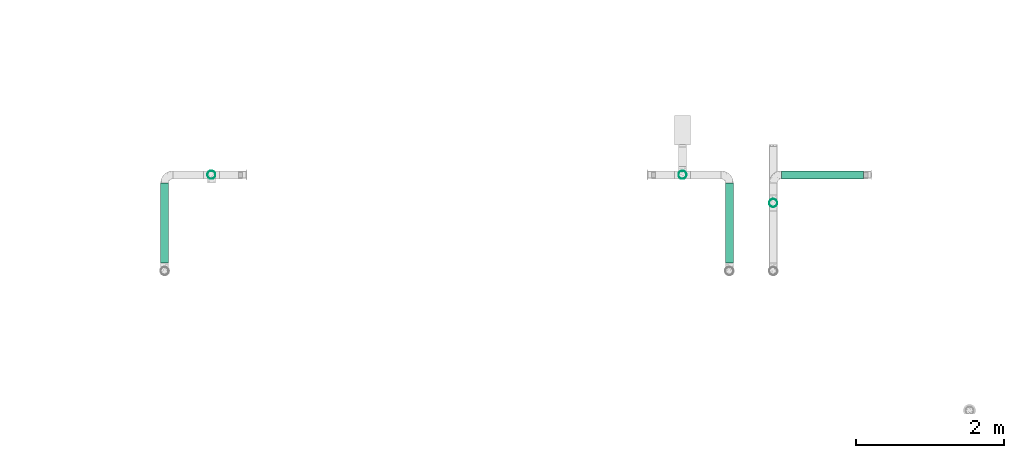
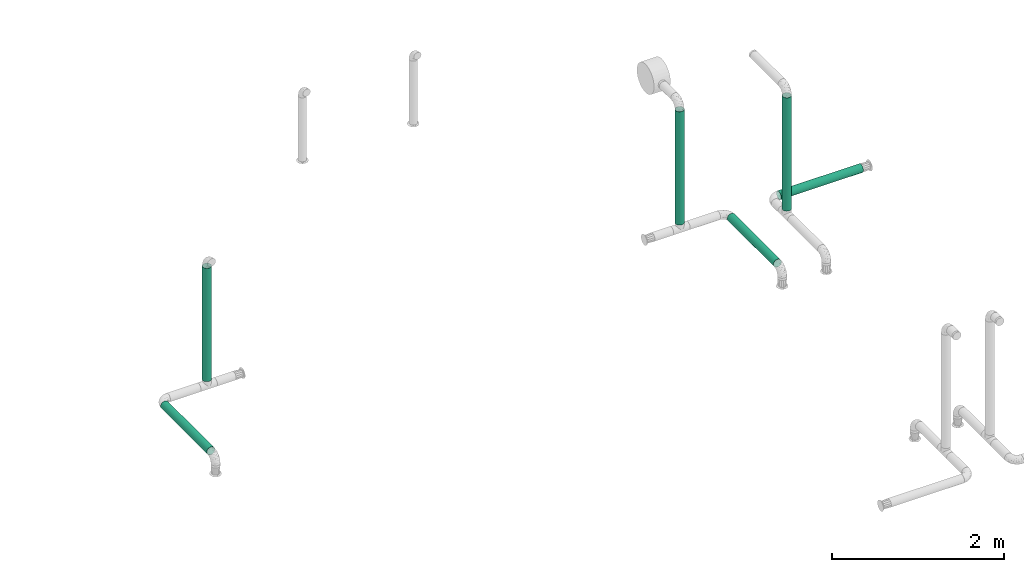
# One storey, part 4 of 103: 6 flow segments.
"""IFC2X3 building model written with IfcOpenShell, lengths in millimetres."""

from ifc_helpers import new_model, entity, si_unit, converted_unit, derived_unit, direction, frame, origin_with_axes, origin_2d_with_axis, place, context, subcontext, project, spatial, hollow_circle, extrude, source, transform, mapped, material, layer, layer_set, layer_usage, type_object, element, save


model = new_model("IFC2X3")

# Units and contexts
model_context = context("Model", 3, precision=1e-05, world=origin_with_axes(), true_north=direction((0.0, 1.0)))
body_context = subcontext(model_context, "Body", "Model", "MODEL_VIEW")
ifc_project = project(units=[si_unit("AREAUNIT", "SQUARE_METRE"), si_unit("VOLUMEUNIT", "CUBIC_METRE", prefix="DECI"), si_unit("TIMEUNIT", "SECOND"), si_unit("THERMODYNAMICTEMPERATUREUNIT", "DEGREE_CELSIUS"), si_unit("PRESSUREUNIT", "PASCAL"), si_unit("MASSUNIT", "GRAM", prefix="KILO"), si_unit("LENGTHUNIT", "METRE", prefix="MILLI"), si_unit("POWERUNIT", "WATT"), si_unit("ELECTRICCURRENTUNIT", "AMPERE"), si_unit("ELECTRICVOLTAGEUNIT", "VOLT"), derived_unit("VOLUMETRICFLOWRATEUNIT", [(si_unit("VOLUMEUNIT", "CUBIC_METRE", prefix="DECI"), 1), (si_unit("TIMEUNIT", "SECOND"), -1)]), derived_unit("LINEARVELOCITYUNIT", [(si_unit("LENGTHUNIT", "METRE"), 1), (si_unit("TIMEUNIT", "SECOND"), -1)]), derived_unit("MASSDENSITYUNIT", [(si_unit("MASSUNIT", "GRAM", prefix="KILO"), 1), (si_unit("VOLUMEUNIT", "CUBIC_METRE"), -1)]), converted_unit("PLANEANGLEUNIT", "DEGREE", entity("IfcRatioMeasure", 0.01745), si_unit("PLANEANGLEUNIT", "RADIAN"), dimensions=[0, 0, 0, 0, 0, 0, 0])], contexts=[model_context])

# Site, building, storey
site_placement = place(None, origin_with_axes())
site = spatial("IfcSite", under=ifc_project, at=site_placement, CompositionType="ELEMENT")
building_placement = place(site_placement, origin_with_axes())
building = spatial("IfcBuilding", under=site, at=building_placement, Name="mc-building", CompositionType="ELEMENT")
storey_placement = place(building_placement, frame((0.0, 0.0, 5900.0), z_axis=(0.0, 0.0, 1.0), x_axis=(1.0, 0.0, 0.0)))
storey = spatial("IfcBuildingStorey", under=building, at=storey_placement, Name="3. Korrus", CompositionType="ELEMENT", Elevation=5900.0)

# Flow segments
ifc_material = material(Name="FZ1")
ifc_layer = layer(ifc_material, 0.0)
ifc_layer_set = layer_set([ifc_layer], Name="FZ1")
ifc_layer_usage = layer_usage(ifc_layer_set, "AXIS1", "POSITIVE", 0.0)
duct_segment_type_1 = type_object("IfcDuctSegmentType", PredefinedType="RIGIDSEGMENT")
shared_shape_1 = source(origin_with_axes(), body_context, "Body", "SweptSolid", [
    extrude(hollow_circle(Radius=55.0, WallThickness=2.0, at=origin_2d_with_axis()), frame((0.0, 0.0, 0.0), z_axis=(1.0, 0.0, 0.0), x_axis=(0.0, 1.0, 0.0)), (0.0, 0.0, 1.0), 1074.1),
])
flow_segment_1_placement = place(storey_placement, frame((18696.22014, 9367.62755, 2345.0), z_axis=(0.0, 0.0, 1.0), x_axis=(0.0, -1.0, 0.0)))
element("IfcFlowSegment", 1, at=flow_segment_1_placement, inside=storey, type_object=duct_segment_type_1, material=ifc_layer_usage, context=body_context, shape_type="MappedRepresentation", body=[
    mapped(shared_shape_1, transform((0.0, 0.0, 0.0), scale=1.0)),
])
duct_segment_type_2 = type_object("IfcDuctSegmentType", Name="Safe", PredefinedType="RIGIDSEGMENT")
flow_segment_2_placement = place(storey_placement, frame((26302.64841, 9367.62755, 2345.0), z_axis=(0.0, 0.0, 1.0), x_axis=(0.0, -1.0, 0.0)))
element("IfcFlowSegment", 2, at=flow_segment_2_placement, inside=storey, type_object=duct_segment_type_2, material=ifc_layer_usage, Name="Safe", context=body_context, shape_type="MappedRepresentation", body=[
    mapped(shared_shape_1, transform((0.0, 0.0, 0.0), scale=1.0)),
])
shared_shape_2 = source(origin_with_axes(), body_context, "Body", "SweptSolid", [
    extrude(hollow_circle(Radius=55.0, WallThickness=2.0, at=origin_2d_with_axis()), frame((0.0, 0.0, 0.0), z_axis=(1.0, 0.0, 0.0), x_axis=(0.0, 1.0, 0.0)), (0.0, 0.0, 1.0), 1609.0),
])
flow_segment_3_placement = place(storey_placement, frame((19326.27346, 9477.62755, 2425.0), z_axis=(-1.0, 0.0, 0.0), x_axis=(0.0, 0.0, 1.0)))
element("IfcFlowSegment", 3, at=flow_segment_3_placement, inside=storey, type_object=duct_segment_type_1, material=ifc_layer_usage, context=body_context, shape_type="MappedRepresentation", body=[
    mapped(shared_shape_2, transform((0.0, 0.0, 0.0), scale=1.0)),
])
for number, where, z_axis, x_axis, name in (
    (4, (25672.59509, 9477.62755, 2425.0), (1.0, 0.0, 0.0), (0.0, 0.0, 1.0), "Safe"),
    (5, (26894.1474, 9098.55564, 2425.0), (0.0, 1.0, 0.0), (0.0, 0.0, 1.0), "Safe"),
):
    element("IfcFlowSegment", number, at=place(storey_placement, frame(where, z_axis=z_axis, x_axis=x_axis)), inside=storey, type_object=duct_segment_type_2, material=ifc_layer_usage, Name=name, context=body_context, shape_type="MappedRepresentation", body=[
        mapped(shared_shape_2, transform((0.0, 0.0, 0.0), scale=1.0)),
    ])
shared_shape_3 = source(origin_with_axes(), body_context, "Body", "SweptSolid", [
    extrude(hollow_circle(Radius=55.0, WallThickness=2.0, at=origin_2d_with_axis()), frame((0.0, 0.0, 0.0), z_axis=(1.0, 0.0, 0.0), x_axis=(0.0, 1.0, 0.0)), (0.0, 0.0, 1.0), 1104.7),
])
flow_segment_4_placement = place(storey_placement, frame((28108.81103, 9477.62755, 2345.0), z_axis=(0.0, 0.0, 1.0), x_axis=(-1.0, 0.0, 0.0)))
element("IfcFlowSegment", 6, at=flow_segment_4_placement, inside=storey, type_object=duct_segment_type_2, material=ifc_layer_usage, Name="Safe", context=body_context, shape_type="MappedRepresentation", body=[
    mapped(shared_shape_3, transform((0.0, 0.0, 0.0), scale=1.0)),
])

save(model, "model.ifc")
